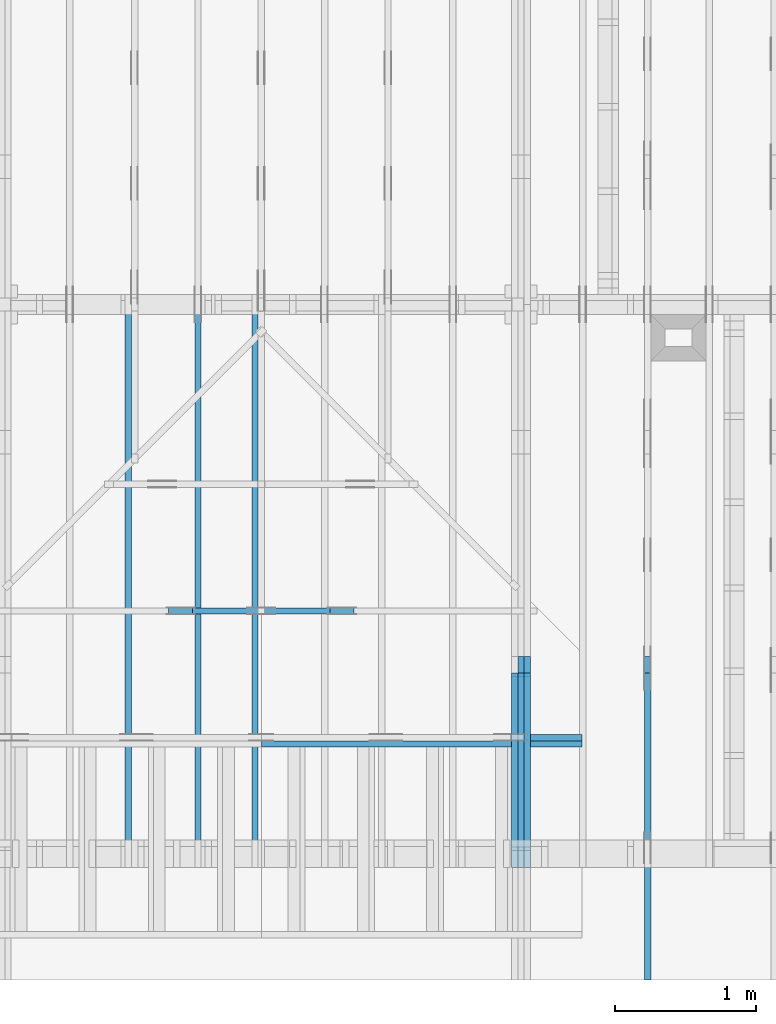
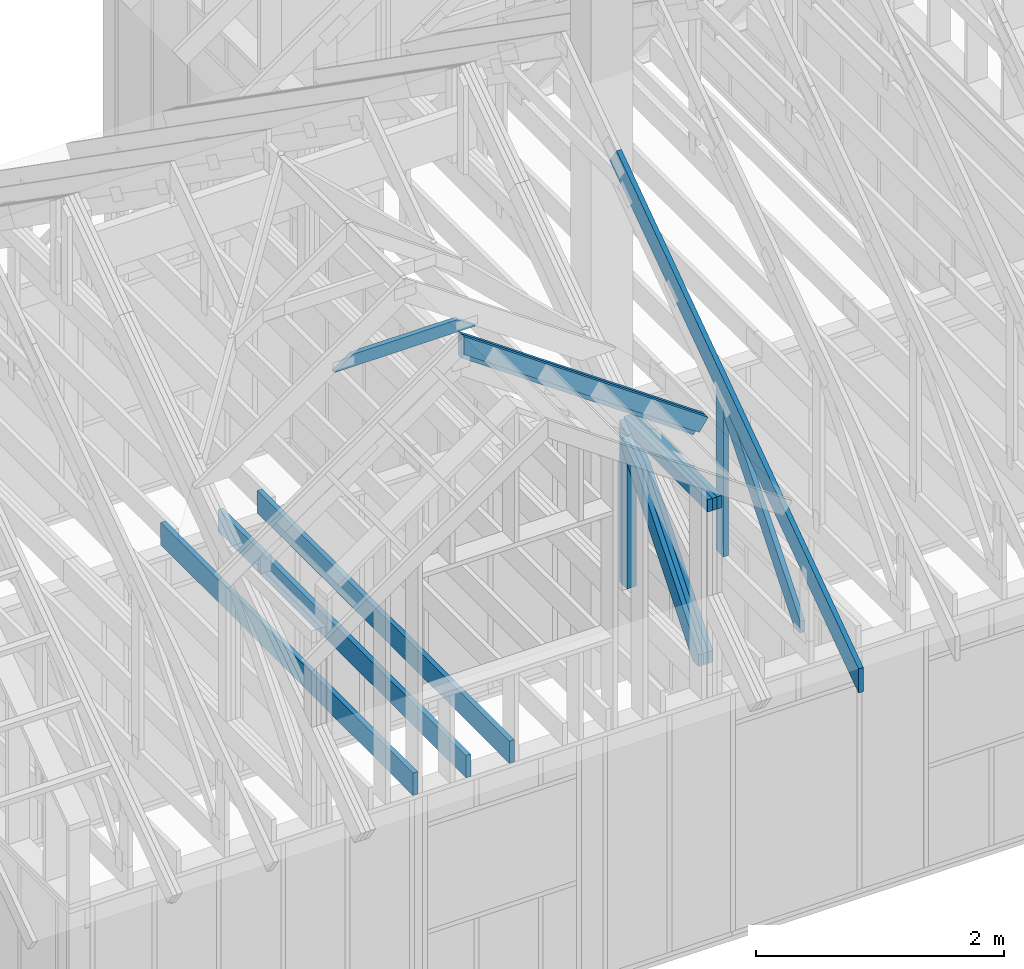
# One storey, part 8 of 70: 17 members, 8 elements without a shape of their own.
"""IFC2X3 building model written with IfcOpenShell, lengths in millimetres."""

from ifc_helpers import new_model, si_unit, frame, origin, origin_with_axes, origin_2d, place, context, project, spatial, faceted_brep, element, aggregate, save


model = new_model("IFC2X3")

# Units and contexts
model_context = context("Model", 3, precision=1e-05, world=origin())
plan_context = context("Plan", 2, precision=1e-05, world=origin_2d())
ifc_project = project(units=[si_unit("LENGTHUNIT", "METRE", prefix="MILLI"), si_unit("AREAUNIT", "SQUARE_METRE"), si_unit("VOLUMEUNIT", "CUBIC_METRE"), si_unit("SOLIDANGLEUNIT", "STERADIAN"), si_unit("PLANEANGLEUNIT", "RADIAN"), si_unit("MASSUNIT", "GRAM"), si_unit("TIMEUNIT", "SECOND"), si_unit("THERMODYNAMICTEMPERATUREUNIT", "DEGREE_CELSIUS"), si_unit("LUMINOUSINTENSITYUNIT", "LUMEN")], contexts=[model_context, plan_context])

# Site, building, storey
site_placement = place(None, origin_with_axes())
site = spatial("IfcSite", under=ifc_project, at=site_placement, CompositionType="ELEMENT")
building_placement = place(site_placement, origin_with_axes())
building = spatial("IfcBuilding", under=site, at=building_placement, Name="Layout 1", CompositionType="ELEMENT")
storey_placement = place(building_placement, origin_with_axes())
storey = spatial("IfcBuildingStorey", under=building, at=storey_placement, Name="Storey 1", CompositionType="ELEMENT", Elevation=0.0)

# Assembly, members
assembly_1_placement = place(storey_placement, frame((5660.000000000293, 8000.0, 9.122500660690286e-13), z_axis=(-1.0, 1.836909530733566e-16, 6.123031769111886e-17), x_axis=(-1.836909530733566e-16, -1.0, 0.0)))
assembly_1 = element("IfcElementAssembly", 1, at=assembly_1_placement, inside=storey, Name="T11", AssemblyPlace="FACTORY", PredefinedType="TRUSS")
member_1_placement = place(assembly_1_placement, frame((6619.9999999949505, 219.99999999999994, -135.0), z_axis=(0.0, 0.0, 1.0), x_axis=(5.053195275411815e-16, 1.0, 0.0)))
member_1 = element("IfcMember", 2, at=member_1_placement, Name="R1", context=model_context, shape_type="Brep", body=[
    faceted_brep([(1592.2602625099316, 120.00000000000091, 45.0), (0.0, 120.00000000000091, 45.0), (5.684341886080802e-14, 0.0, 45.0), (1508.2353579246992, 0.0, 45.0), (0.0, 120.00000000000091, 0.0), (1592.2602625099316, 120.00000000000091, 1.9498920344085486e-13), (1508.2353579246992, 0.0, 1.846994602374154e-13), (5.684341886080802e-14, 0.0, 6.961081190993225e-30), (5.684341886080802e-14, 0.0, 0.0), (5.959878315690836e-14, 8.86203890694297e-31, 45.0), (2.1003354220769377e-14, 120.0, 45.0), (1.8247989924669028e-14, 120.0, -1.1173302203118208e-30), (1508.2353579246992, -2.7704919035612314e-13, 7.265245946951848e-29), (1508.2353579246992, -2.742938260600228e-13, 45.0), (5.684341886080802e-14, 2.7553642961003043e-15, 45.0), (5.684341886080802e-14, -4.4719288075722504e-29, 2.7381762157971524e-45), (1592.260262509932, 120.00000000000057, 1.9009198412843567e-29), (1592.260262509932, 120.00000000000057, 45.0), (1508.2353579246997, 6.821210263296962e-13, 45.0), (1508.2353579246997, 6.821210263296962e-13, 3.2533805409343593e-29), (0.0, 120.0, 0.0), (0.0, 120.0, 45.0), (1592.2602625099316, 120.00000000000131, 45.0), (1592.2602625099316, 120.00000000000132, 2.524354896707238e-29)], [[[0, 1, 2, 3]], [[4, 5, 6, 7]], [[8, 9, 10, 11]], [[12, 13, 14, 15]], [[16, 17, 18, 19]], [[20, 21, 22, 23]]]),
])
member_2_placement = place(assembly_1_placement, frame((6619.9999999949505, 219.99999999999994, -180.0), z_axis=(0.0, 0.0, 1.0), x_axis=(5.053195275411815e-16, 1.0, 0.0)))
member_2 = element("IfcMember", 3, at=member_2_placement, Name="R1", context=model_context, shape_type="Brep", body=[
    faceted_brep([(1592.2602625099316, 120.00000000000091, 45.0), (0.0, 120.00000000000091, 45.0), (5.684341886080802e-14, 0.0, 45.0), (1508.2353579246992, 0.0, 45.0), (0.0, 120.00000000000091, 0.0), (1592.2602625099316, 120.00000000000091, 1.9498920344085486e-13), (1508.2353579246992, 0.0, 1.846994602374154e-13), (5.684341886080802e-14, 0.0, 6.961081190993225e-30), (5.684341886080802e-14, 0.0, 0.0), (5.959878315690836e-14, 8.86203890694297e-31, 45.0), (2.1003354220769377e-14, 120.0, 45.0), (1.8247989924669028e-14, 120.0, -1.1173302203118208e-30), (1508.2353579246992, -2.7704919035612314e-13, 7.265245946951848e-29), (1508.2353579246992, -2.742938260600228e-13, 45.0), (5.684341886080802e-14, 2.7553642961003043e-15, 45.0), (5.684341886080802e-14, -4.4719288075722504e-29, 2.7381762157971524e-45), (1592.260262509932, 120.00000000000057, 1.9009198412843567e-29), (1592.260262509932, 120.00000000000057, 45.0), (1508.2353579246997, 6.821210263296962e-13, 45.0), (1508.2353579246997, 6.821210263296962e-13, 3.2533805409343593e-29), (0.0, 120.0, 0.0), (0.0, 120.0, 45.0), (1592.2602625099316, 120.00000000000131, 45.0), (1592.2602625099316, 120.00000000000132, 2.524354896707238e-29)], [[[0, 1, 2, 3]], [[4, 5, 6, 7]], [[8, 9, 10, 11]], [[12, 13, 14, 15]], [[16, 17, 18, 19]], [[20, 21, 22, 23]]]),
])
member_3_placement = place(assembly_1_placement, frame((6563.906131857986, 1682.303582896796, -90.00000000000001), z_axis=(0.0, 0.0, 1.0), x_axis=(0.6335417245359882, -0.7737085260432164, 0.0)))
member_3 = element("IfcMember", 4, at=member_3_placement, Name="W6", context=model_context, shape_type="Brep", body=[
    faceted_brep([(1860.8184531642582, 145.00000000000364, 45.0), (258.1329393215924, 145.00000000000364, 45.0), (0.0, 72.49999999849206, 45.0), (88.54013234574177, 0.0, 45.0), (1889.9928508932062, 0.0, 45.0), (1949.358585511326, 72.49999999849206, 45.0), (258.1329393215924, 145.00000000000364, 3.1611123762406824e-14), (1860.8184531642582, 145.00000000000364, 2.2787701010548785e-13), (1949.358585511326, 72.49999999849206, 2.3871969096953717e-13), (1889.9928508932062, 0.0, 2.3144972538826894e-13), (88.54013234574177, 0.0, 1.0842680863886955e-14), (0.0, 72.49999999849206, 0.0), (7.105427357601002e-15, 72.49999999849206, 1.7516230804060213e-46), (7.105427357601002e-15, 72.49999999849206, 45.0), (258.13293932159246, 145.0, 45.0), (258.13293932159246, 145.0, 1.7516230804060213e-46), (88.54013234574177, -2.842170943040401e-14, 2.3665827156630354e-30), (88.54013234574177, -2.842170943040401e-14, 45.0), (7.105427357601002e-15, 72.49999999849209, 45.0), (7.105427357601002e-15, 72.49999999849209, -1.1832913578315177e-30), (1889.9928508932062, 2.7866220188636956e-12, 1.0781749613963793e-28), (1889.9928508932062, 2.789377383159796e-12, 45.0), (88.54013234574177, -7.973490750159428e-14, 45.0), (88.54013234574177, -8.249027179769463e-14, 5.0509055485995835e-30), (1949.358585511326, 72.50000000000239, 1.262177448353619e-29), (1949.358585511326, 72.50000000000239, 45.0), (1889.9928508932062, 4.206412995699793e-12, 45.0), (1889.9928508932062, 4.206412995699793e-12, 1.262177448353619e-29), (1860.8184531642582, 145.00000000000364, -1.262177448353619e-29), (1860.8184531642582, 145.00000000000364, 45.0), (1949.358585511326, 72.50000000000261, 45.0), (1949.358585511326, 72.50000000000261, -1.262177448353619e-29), (258.1329393215924, 144.99999999999997, -1.5777218104420236e-30), (258.1329393215924, 144.99999999999997, 45.0), (1860.8184531642582, 145.0000000000034, 45.0), (1860.8184531642582, 145.0000000000034, -1.262177448353619e-29)], [[[0, 1, 2, 3, 4, 5]], [[6, 7, 8, 9, 10, 11]], [[12, 13, 14, 15]], [[16, 17, 18, 19]], [[20, 21, 22, 23]], [[24, 25, 26, 27]], [[28, 29, 30, 31]], [[32, 33, 34, 35]]]),
])
member_4_placement = place(assembly_1_placement, frame((6563.906131857986, 1682.303582896796, -135.00000000000003), z_axis=(0.0, 0.0, 1.0), x_axis=(0.6335417245359882, -0.7737085260432164, 0.0)))
member_4 = element("IfcMember", 5, at=member_4_placement, Name="W6", context=model_context, shape_type="Brep", body=[
    faceted_brep([(1860.8184531642582, 145.00000000000364, 45.0), (258.1329393215924, 145.00000000000364, 45.0), (0.0, 72.49999999849206, 45.0), (88.54013234574177, 0.0, 45.0), (1889.9928508932062, 0.0, 45.0), (1949.358585511326, 72.49999999849206, 45.0), (258.1329393215924, 145.00000000000364, 3.1611123762406824e-14), (1860.8184531642582, 145.00000000000364, 2.2787701010548785e-13), (1949.358585511326, 72.49999999849206, 2.3871969096953717e-13), (1889.9928508932062, 0.0, 2.3144972538826894e-13), (88.54013234574177, 0.0, 1.0842680863886955e-14), (0.0, 72.49999999849206, 0.0), (7.105427357601002e-15, 72.49999999849206, 1.7516230804060213e-46), (7.105427357601002e-15, 72.49999999849206, 45.0), (258.13293932159246, 145.0, 45.0), (258.13293932159246, 145.0, 1.7516230804060213e-46), (88.54013234574177, -2.842170943040401e-14, 2.3665827156630354e-30), (88.54013234574177, -2.842170943040401e-14, 45.0), (7.105427357601002e-15, 72.49999999849209, 45.0), (7.105427357601002e-15, 72.49999999849209, -1.1832913578315177e-30), (1889.9928508932062, 2.7866220188636956e-12, 1.0781749613963793e-28), (1889.9928508932062, 2.789377383159796e-12, 45.0), (88.54013234574177, -7.973490750159428e-14, 45.0), (88.54013234574177, -8.249027179769463e-14, 5.0509055485995835e-30), (1949.358585511326, 72.50000000000239, 1.262177448353619e-29), (1949.358585511326, 72.50000000000239, 45.0), (1889.9928508932062, 4.206412995699793e-12, 45.0), (1889.9928508932062, 4.206412995699793e-12, 1.262177448353619e-29), (1860.8184531642582, 145.00000000000364, -1.262177448353619e-29), (1860.8184531642582, 145.00000000000364, 45.0), (1949.358585511326, 72.50000000000261, 45.0), (1949.358585511326, 72.50000000000261, -1.262177448353619e-29), (258.1329393215924, 144.99999999999997, -1.5777218104420236e-30), (258.1329393215924, 144.99999999999997, 45.0), (1860.8184531642582, 145.0000000000034, 45.0), (1860.8184531642582, 145.0000000000034, -1.262177448353619e-29)], [[[0, 1, 2, 3, 4, 5]], [[6, 7, 8, 9, 10, 11]], [[12, 13, 14, 15]], [[16, 17, 18, 19]], [[20, 21, 22, 23]], [[24, 25, 26, 27]], [[28, 29, 30, 31]], [[32, 33, 34, 35]]]),
])
member_5_placement = place(assembly_1_placement, frame((6563.906131857986, 1682.303582896796, -180.00000000000003), z_axis=(0.0, 0.0, 1.0), x_axis=(0.6335417245359882, -0.7737085260432164, 0.0)))
member_5 = element("IfcMember", 6, at=member_5_placement, Name="W6", context=model_context, shape_type="Brep", body=[
    faceted_brep([(1860.8184531642582, 145.00000000000364, 45.0), (258.1329393215924, 145.00000000000364, 45.0), (0.0, 72.49999999849206, 45.0), (88.54013234574177, 0.0, 45.0), (1889.9928508932062, 0.0, 45.0), (1949.358585511326, 72.49999999849206, 45.0), (258.1329393215924, 145.00000000000364, 3.1611123762406824e-14), (1860.8184531642582, 145.00000000000364, 2.2787701010548785e-13), (1949.358585511326, 72.49999999849206, 2.3871969096953717e-13), (1889.9928508932062, 0.0, 2.3144972538826894e-13), (88.54013234574177, 0.0, 1.0842680863886955e-14), (0.0, 72.49999999849206, 0.0), (7.105427357601002e-15, 72.49999999849206, 1.7516230804060213e-46), (7.105427357601002e-15, 72.49999999849206, 45.0), (258.13293932159246, 145.0, 45.0), (258.13293932159246, 145.0, 1.7516230804060213e-46), (88.54013234574177, -2.842170943040401e-14, 2.3665827156630354e-30), (88.54013234574177, -2.842170943040401e-14, 45.0), (7.105427357601002e-15, 72.49999999849209, 45.0), (7.105427357601002e-15, 72.49999999849209, -1.1832913578315177e-30), (1889.9928508932062, 2.7866220188636956e-12, 1.0781749613963793e-28), (1889.9928508932062, 2.789377383159796e-12, 45.0), (88.54013234574177, -7.973490750159428e-14, 45.0), (88.54013234574177, -8.249027179769463e-14, 5.0509055485995835e-30), (1949.358585511326, 72.50000000000239, 1.262177448353619e-29), (1949.358585511326, 72.50000000000239, 45.0), (1889.9928508932062, 4.206412995699793e-12, 45.0), (1889.9928508932062, 4.206412995699793e-12, 1.262177448353619e-29), (1860.8184531642582, 145.00000000000364, -1.262177448353619e-29), (1860.8184531642582, 145.00000000000364, 45.0), (1949.358585511326, 72.50000000000261, 45.0), (1949.358585511326, 72.50000000000261, -1.262177448353619e-29), (258.1329393215924, 144.99999999999997, -1.5777218104420236e-30), (258.1329393215924, 144.99999999999997, 45.0), (1860.8184531642582, 145.0000000000034, 45.0), (1860.8184531642582, 145.0000000000034, -1.262177448353619e-29)], [[[0, 1, 2, 3, 4, 5]], [[6, 7, 8, 9, 10, 11]], [[12, 13, 14, 15]], [[16, 17, 18, 19]], [[20, 21, 22, 23]], [[24, 25, 26, 27]], [[28, 29, 30, 31]], [[32, 33, 34, 35]]]),
])
member_6_placement = place(assembly_1_placement, frame((8000.000000000239, 1950.43961597234, -90.0), z_axis=(0.0, 0.0, 1.0), x_axis=(-1.0, -7.792541026514777e-13, 0.0)))
member_6 = element("IfcMember", 7, at=member_6_placement, Name="T20", context=model_context, shape_type="Brep", body=[
    faceted_brep([(1185.9906822582107, 120.00000000718114, 45.0), (0.0, 120.00000000718114, 45.0), (2.3919710656628013e-10, 0.0, 45.0), (1357.3684430670319, 0.0, 45.0), (0.0, 120.00000000718114, 0.0), (1185.9906822582107, 120.00000000718114, 1.452371725067541e-13), (1357.3684430670319, 0.0, 1.662242019857875e-13), (2.3919710656628013e-10, 0.0, 2.929222965169949e-26), (2.3919710656628013e-10, 0.0, 0.0), (2.3919986193057623e-10, 5.491303034653426e-27, 45.0), (4.5872349972372883e-14, 120.0, 45.0), (4.3116985676272535e-14, 120.0, -2.6400667308415888e-30), (1357.3684430670319, 7.185039401631766e-09, 5.377473518020143e-29), (1357.3684430670319, 7.185042156996062e-09, 45.0), (2.3919710656628013e-10, 2.755364295945585e-15, 45.0), (2.3919710656628013e-10, -1.5476399835663503e-25, 9.476248786526727e-42), (1185.9906822582107, 120.00000000718126, 7.47707513912535e-31), (1185.9906822582107, 120.00000000718126, 45.0), (1357.3684430670319, 7.185803951870184e-09, 45.0), (1357.3684430670319, 7.185803951870184e-09, -5.4167093989721165e-31), (0.0, 120.0, 0.0), (0.0, 120.0, 45.0), (1185.9906822582107, 120.00000000718101, 45.0), (1185.9906822582107, 120.00000000718103, -6.310887241768095e-30)], [[[0, 1, 2, 3]], [[4, 5, 6, 7]], [[8, 9, 10, 11]], [[12, 13, 14, 15]], [[16, 17, 18, 19]], [[20, 21, 22, 23]]]),
])
member_7_placement = place(assembly_1_placement, frame((8000.000000000239, 1950.43961597234, -135.0), z_axis=(0.0, 0.0, 1.0), x_axis=(-1.0, -7.792541026514777e-13, 0.0)))
member_7 = element("IfcMember", 8, at=member_7_placement, Name="T20", context=model_context, shape_type="Brep", body=[
    faceted_brep([(1185.9906822582107, 120.00000000718114, 45.0), (0.0, 120.00000000718114, 45.0), (2.3919710656628013e-10, 0.0, 45.0), (1357.3684430670319, 0.0, 45.0), (0.0, 120.00000000718114, 0.0), (1185.9906822582107, 120.00000000718114, 1.452371725067541e-13), (1357.3684430670319, 0.0, 1.662242019857875e-13), (2.3919710656628013e-10, 0.0, 2.929222965169949e-26), (2.3919710656628013e-10, 0.0, 0.0), (2.3919986193057623e-10, 5.491303034653426e-27, 45.0), (4.5872349972372883e-14, 120.0, 45.0), (4.3116985676272535e-14, 120.0, -2.6400667308415888e-30), (1357.3684430670319, 7.185039401631766e-09, 5.377473518020143e-29), (1357.3684430670319, 7.185042156996062e-09, 45.0), (2.3919710656628013e-10, 2.755364295945585e-15, 45.0), (2.3919710656628013e-10, -1.5476399835663503e-25, 9.476248786526727e-42), (1185.9906822582107, 120.00000000718126, 7.47707513912535e-31), (1185.9906822582107, 120.00000000718126, 45.0), (1357.3684430670319, 7.185803951870184e-09, 45.0), (1357.3684430670319, 7.185803951870184e-09, -5.4167093989721165e-31), (0.0, 120.0, 0.0), (0.0, 120.0, 45.0), (1185.9906822582107, 120.00000000718101, 45.0), (1185.9906822582107, 120.00000000718103, -6.310887241768095e-30)], [[[0, 1, 2, 3]], [[4, 5, 6, 7]], [[8, 9, 10, 11]], [[12, 13, 14, 15]], [[16, 17, 18, 19]], [[20, 21, 22, 23]]]),
])
member_8_placement = place(assembly_1_placement, frame((8000.000000000239, 1950.43961597234, -180.0), z_axis=(0.0, 0.0, 1.0), x_axis=(-1.0, -7.792541026514777e-13, 0.0)))
member_8 = element("IfcMember", 9, at=member_8_placement, Name="T20", context=model_context, shape_type="Brep", body=[
    faceted_brep([(1185.9906822582107, 120.00000000718114, 45.0), (0.0, 120.00000000718114, 45.0), (2.3919710656628013e-10, 0.0, 45.0), (1357.3684430670319, 0.0, 45.0), (0.0, 120.00000000718114, 0.0), (1185.9906822582107, 120.00000000718114, 1.452371725067541e-13), (1357.3684430670319, 0.0, 1.662242019857875e-13), (2.3919710656628013e-10, 0.0, 2.929222965169949e-26), (2.3919710656628013e-10, 0.0, 0.0), (2.3919986193057623e-10, 5.491303034653426e-27, 45.0), (4.5872349972372883e-14, 120.0, 45.0), (4.3116985676272535e-14, 120.0, -2.6400667308415888e-30), (1357.3684430670319, 7.185039401631766e-09, 5.377473518020143e-29), (1357.3684430670319, 7.185042156996062e-09, 45.0), (2.3919710656628013e-10, 2.755364295945585e-15, 45.0), (2.3919710656628013e-10, -1.5476399835663503e-25, 9.476248786526727e-42), (1185.9906822582107, 120.00000000718126, 7.47707513912535e-31), (1185.9906822582107, 120.00000000718126, 45.0), (1357.3684430670319, 7.185803951870184e-09, 45.0), (1357.3684430670319, 7.185803951870184e-09, -5.4167093989721165e-31), (0.0, 120.0, 0.0), (0.0, 120.0, 45.0), (1185.9906822582107, 120.00000000718101, 45.0), (1185.9906822582107, 120.00000000718103, -6.310887241768095e-30)], [[[0, 1, 2, 3]], [[4, 5, 6, 7]], [[8, 9, 10, 11]], [[12, 13, 14, 15]], [[16, 17, 18, 19]], [[20, 21, 22, 23]]]),
])
aggregate(assembly_1, [member_1, member_2, member_3, member_4, member_5, member_6, member_7, member_8])

# Assembly, member
assembly_2_placement = place(storey_placement, frame((3455.0000000000005, 8000.000000000001, 1.3776821480501744e-15), z_axis=(-1.0, 1.836909530733566e-16, 6.123031769111886e-17), x_axis=(-1.836909530733566e-16, -1.0, 0.0)))
assembly_2 = element("IfcElementAssembly", 10, at=assembly_2_placement, inside=storey, Name="MB1", AssemblyPlace="FACTORY", PredefinedType="TRUSS")
member_9_placement = place(assembly_2_placement, frame((8000.000000000001, 220.0, -45.0), z_axis=(0.0, 0.0, 1.0), x_axis=(-1.0, 1.2246063538223773e-16, 0.0)))
member_9 = element("IfcMember", 11, at=member_9_placement, Name="B3", context=model_context, shape_type="Brep", body=[
    faceted_brep([(4000.0000000000005, 220.0000000000005, 45.0), (0.0, 220.0000000000005, 45.0), (0.0, 0.0, 45.0), (4000.0000000000005, 0.0, 45.0), (0.0, 220.0000000000005, 0.0), (4000.0000000000005, 220.0000000000005, 4.89842541528951e-13), (4000.0000000000005, 0.0, 4.89842541528951e-13), (0.0, 0.0, 0.0), (0.0, 0.0, 0.0), (2.755364296100349e-15, -3.3742366240998092e-31, 45.0), (2.969670408019265e-14, 220.0, 45.0), (2.69413397840923e-14, 220.0, -1.6496267940043512e-30), (4000.0000000000005, -7.347638122934265e-13, 7.631468701413364e-29), (4000.0000000000005, -7.320084479973261e-13, 45.0), (5.061354936149714e-31, 2.755364296100349e-15, 45.0), (0.0, 0.0, 0.0), (4000.0000000000005, 220.0000000000005, 0.0), (4000.0000000000005, 220.0000000000005, 45.0), (4000.0000000000005, 5.115907697472721e-13, 45.0), (4000.0000000000005, 5.115907697472721e-13, 0.0), (0.0, 220.0, 0.0), (0.0, 220.0, 45.0), (4000.0000000000005, 220.00000000000065, 45.0), (4000.0000000000005, 220.00000000000065, 7.888609052210118e-30)], [[[0, 1, 2, 3]], [[4, 5, 6, 7]], [[8, 9, 10, 11]], [[12, 13, 14, 15]], [[16, 17, 18, 19]], [[20, 21, 22, 23]]]),
])
aggregate(assembly_2, [member_9])

assembly_3_placement = place(storey_placement, frame((6205.00000000017, 945.0, 1.3776821480501744e-15), z_axis=(1.2246063538223773e-16, 1.0, 6.123031769111886e-17), x_axis=(-1.0, 1.2246063538223773e-16, 0.0)))
assembly_3 = element("IfcElementAssembly", 12, at=assembly_3_placement, inside=storey, Name="T7", AssemblyPlace="FACTORY", PredefinedType="TRUSS")
member_10_placement = place(assembly_3_placement, frame((111.84740508874393, 1910.1615822583046, -45.0), z_axis=(0.0, 0.0, 1.0), x_axis=(0.8191520442889916, 0.5735764363510464, 0.0)))
member_10 = element("IfcMember", 13, at=member_10_placement, Name="T14", context=model_context, shape_type="Brep", body=[
    faceted_brep([(2780.314125903724, 194.9999999995032, 45.0), (0.0, 194.9999999995032, 45.0), (3.9267433749046177e-10, 0.0, 45.0), (2643.7736559537752, 0.0, 45.0), (0.0, 194.9999999995032, 0.0), (2780.314125903724, 194.9999999995032, 3.404790344203809e-13), (2643.7736559537752, 0.0, 3.237582017149209e-13), (3.9267433749046177e-10, 0.0, 4.80871488673812e-26), (3.926743374904618e-10, 9.4039548065783e-38, -2.8698592549372254e-42), (3.926770928547579e-10, 5.5475899021902624e-27, 45.0), (6.837957290390364e-14, 195.00000000050545, 45.0), (6.56242086078033e-14, 195.00000000050545, -4.018191141284025e-30), (2643.7736559537752, 8.495420229172257e-10, 1.2077016536174847e-28), (2643.7736559537752, 8.495447782815218e-10, 45.0), (3.9267433749046177e-10, 2.7553642958073935e-15, 45.0), (3.9267433749046177e-10, -2.9295532543016987e-25, 1.7937747645394064e-41), (2780.3141259037243, 194.99999999950296, 5.048709793414476e-29), (2780.3141259037243, 194.99999999950296, 45.0), (2643.7736559537757, 8.512870408594608e-10, 45.0), (2643.7736559537757, 8.512870408594608e-10, 5.048709793414476e-29), (0.0, 195.00000000050545, 0.0), (0.0, 195.00000000050545, 45.0), (2780.314125903724, 194.9999999995033, 45.0), (2780.314125903724, 194.9999999995033, 7.888609052210118e-30)], [[[0, 1, 2, 3]], [[4, 5, 6, 7]], [[8, 9, 10, 11]], [[12, 13, 14, 15]], [[16, 17, 18, 19]], [[20, 21, 22, 23]]]),
])
aggregate(assembly_3, [member_10])

assembly_4_placement = place(storey_placement, frame((5910.470169573801, 1845.0, 1.3776821480501744e-15), z_axis=(1.2246063538223773e-16, 1.0, 6.123031769111886e-17), x_axis=(-1.0, 1.2246063538223773e-16, 0.0)))
assembly_4 = element("IfcElementAssembly", 14, at=assembly_4_placement, inside=storey, Name="T6", AssemblyPlace="FACTORY", PredefinedType="TRUSS")
member_11_placement = place(assembly_4_placement, frame((2642.157380753415, 3084.999999998777, -45.0), z_axis=(0.0, 0.0, 1.0), x_axis=(-1.0, 1.2246063538223773e-16, 0.0)))
member_11 = element("IfcMember", 15, at=member_11_placement, Name="C3", context=model_context, shape_type="Brep", body=[
    faceted_brep([(1318.3744223606627, 120.00000000000728, 45.0), (0.0, 120.00000000000728, 45.0), (171.37776080916228, 6.821210263296962e-12, 45.0), (1146.996661551806, 6.821210263296962e-12, 45.0), (0.0, 120.00000000000728, 0.0), (1318.3744223606627, 120.00000000000728, 1.6144896943397739e-13), (1146.996661551806, 6.821210263296962e-12, 1.4046193995493965e-13), (171.37776080916228, 6.821210263296962e-12, 2.0987029479075173e-14), (171.37776080916223, 6.750155989720952e-12, 5.5220263365470826e-30), (171.37776080916223, 6.750155989720952e-12, 45.0), (7.105427357601002e-15, 119.99999999999955, 45.0), (7.105427357601002e-15, 119.99999999999955, 0.0), (1146.996661551806, -3.4116650145363124e-13, 2.088973326957347e-29), (1146.996661551806, -3.384111371575309e-13, 45.0), (171.37776080916228, 6.772990456485663e-12, 45.0), (171.37776080916228, 6.770235092189562e-12, 3.1212259212651897e-30), (1318.3744223606627, 120.00000000000693, 2.6012554462568004e-29), (1318.3744223606627, 120.00000000000693, 45.0), (1146.996661551806, -2.2737367544323206e-13, 45.0), (1146.996661551806, -2.2737367544323206e-13, 1.841228876698994e-29), (0.0, 119.99999999999955, 0.0), (0.0, 119.99999999999955, 45.0), (1318.3744223606627, 120.00000000000736, 45.0), (1318.3744223606627, 120.00000000000738, 6.310887241768095e-30)], [[[0, 1, 2, 3]], [[4, 5, 6, 7]], [[8, 9, 10, 11]], [[12, 13, 14, 15]], [[16, 17, 18, 19]], [[20, 21, 22, 23]]]),
])
aggregate(assembly_4, [member_11])

# Assembly, members
assembly_5_placement = place(storey_placement, frame((6650.000000000001, 8000.0, -9.081170196248781e-13), z_axis=(-1.0, 1.836909530733566e-16, 6.123031769111886e-17), x_axis=(-1.836909530733566e-16, -1.0, 0.0)))
assembly_5 = element("IfcElementAssembly", 16, at=assembly_5_placement, inside=storey, Name="T12", AssemblyPlace="FACTORY", PredefinedType="TRUSS")
member_12_placement = place(assembly_5_placement, frame((4782.309641269037, 3015.0000000009313, -45.00000000000001), z_axis=(0.0, 0.0, 1.0), x_axis=(0.8191520442889916, -0.5735764363510465, 0.0)))
member_12 = element("IfcMember", 17, at=member_12_placement, Name="T8", context=model_context, shape_type="Brep", body=[
    faceted_brep([(4768.153825500143, 194.99999999946067, 45.0), (1.6370904631912708e-10, 194.99999999946067, 45.0), (0.0, 0.0, 45.0), (4904.694295450093, 0.0, 45.0), (1.6370904631912708e-10, 194.99999999946067, 2.004791383006049e-26), (4768.153825500143, 194.99999999946067, 5.83911147070995e-13), (4904.694295450093, 0.0, 6.006319797764552e-13), (0.0, 0.0, 0.0), (2.5849394142282115e-26, -2.1699301500556333e-38, -1.582766615454881e-42), (2.7553642961261982e-15, -2.3129934990511945e-27, 45.0), (1.6369571347777126e-10, 194.99999999920783, 45.0), (1.6369295811347516e-10, 194.99999999920783, 9.850859431479521e-31), (4904.694295450093, 8.093603669211206e-10, -5.018296283692949e-29), (4904.694295450093, 8.093631222854167e-10, 45.0), (-4.546833142611764e-28, 2.755364296100349e-15, 45.0), (0.0, 0.0, 0.0), (4768.153825500144, 194.99999999946112, 5.048709793414476e-29), (4768.153825500144, 194.99999999946112, 45.0), (4904.694295450094, 8.089955372270197e-10, 45.0), (4904.694295450094, 8.089955372270197e-10, 1.0097419586828951e-28), (1.637090463191271e-10, 194.99999999920783, 0.0), (1.637090463191271e-10, 194.99999999920783, 45.0), (4768.153825500143, 194.99999999946058, 45.0), (4768.153825500143, 194.99999999946058, -6.310887241768095e-30)], [[[0, 1, 2, 3]], [[4, 5, 6, 7]], [[8, 9, 10, 11]], [[12, 13, 14, 15]], [[16, 17, 18, 19]], [[20, 21, 22, 23]]]),
])
member_13_placement = place(assembly_5_placement, frame((6619.999999999389, 220.0, -45.0), z_axis=(0.0, 0.0, 1.0), x_axis=(6.123031769111886e-17, 1.0, 0.0)))
member_13 = element("IfcMember", 18, at=member_13_placement, Name="T5", context=model_context, shape_type="Brep", body=[
    faceted_brep([(1592.2602625068248, 120.0, 45.0), (0.0, 120.0, 45.0), (0.0, 1.4551915228366852e-11, 45.0), (1508.235357921585, 1.4551915228366852e-11, 45.0), (0.0, 120.0, 0.0), (1592.2602625068248, 120.0, 1.949892034404744e-13), (1508.235357921585, 1.4551915228366852e-11, 1.8469946023703405e-13), (0.0, 1.4551915228366852e-11, 0.0), (1.7820367848942657e-27, 1.4551915228366852e-11, -1.0911467847633593e-43), (2.755364296102131e-15, 1.4551915228366852e-11, 45.0), (1.7450640541968876e-14, 120.0, 45.0), (1.4695276245868527e-14, 120.0, -8.997964330932825e-31), (1508.235357921585, -4.605370260698061e-13, 2.81988284147774e-29), (1508.235357921585, -4.577816617737058e-13, 45.0), (2.7425941661909085e-29, 1.4554670592662952e-11, 45.0), (0.0, 1.4551915228366852e-11, 0.0), (1592.260262506825, 120.00000000000011, 1.262177448353619e-29), (1592.260262506825, 120.00000000000011, 45.0), (1508.2353579215853, 0.0, 45.0), (1508.2353579215853, 0.0, 1.262177448353619e-29), (0.0, 120.0, 0.0), (-1.6871183120499046e-31, 120.0, 45.0), (1592.2602625068248, 119.9999999999999, 45.0), (1592.2602625068248, 119.9999999999999, -6.310887241768095e-30)], [[[0, 1, 2, 3]], [[4, 5, 6, 7]], [[8, 9, 10, 11]], [[12, 13, 14, 15]], [[16, 17, 18, 19]], [[20, 21, 22, 23]]]),
])
member_14_placement = place(assembly_5_placement, frame((6563.906131861295, 1682.3035828927568, -45.00000000000001), z_axis=(0.0, 0.0, 1.0), x_axis=(0.6335417245359882, -0.7737085260432164, 0.0)))
member_14 = element("IfcMember", 19, at=member_14_placement, Name="W6", context=model_context, shape_type="Brep", body=[
    faceted_brep([(1860.8184531590405, 145.0, 45.0), (258.1329393189221, 145.0, 45.0), (0.0, 72.4999999999518, 45.0), (88.54013234752438, 0.0, 45.0), (1889.992850887983, 0.0, 45.0), (1949.3585855061046, 72.4999999999518, 45.0), (258.1329393189221, 145.0, 3.161112376207982e-14), (1860.8184531590405, 145.0, 2.278770101048489e-13), (1949.3585855061046, 72.4999999999518, 2.3871969096889775e-13), (1889.992850887983, 0.0, 2.3144972538762927e-13), (88.54013234752438, 0.0, 1.0842680864105255e-14), (0.0, 72.4999999999518, 0.0), (3.552713678800501e-15, 72.4999999999518, -8.492704648590562e-31), (3.552713678800501e-15, 72.4999999999518, 45.0), (258.1329393189221, 145.00000000000003, 45.0), (258.1329393189221, 145.00000000000003, 6.911006666987167e-31), (88.54013234752439, 0.0, 8.758115402030107e-47), (88.54013234752439, 0.0, 45.0), (0.0, 72.49999999995181, 45.0), (0.0, 72.4999999999518, 8.758115402030107e-47), (1889.992850887983, -3.918756121136429e-13, 7.968331775306583e-29), (1889.992850887983, -3.8912024781754257e-13, 45.0), (88.54013234752438, -5.820968103225653e-14, 45.0), (88.54013234752438, -6.096504532835688e-14, 3.7329090935087544e-30), (1949.358585506105, 72.50000000000159, 3.7865323450608567e-29), (1949.358585506105, 72.50000000000159, 45.0), (1889.9928508879834, 6.821210263296962e-13, 45.0), (1889.9928508879834, 6.821210263296962e-13, 3.7865323450608567e-29), (1860.8184531590405, 145.0, 0.0), (1860.8184531590405, 145.0, 45.0), (1949.3585855061046, 72.50000000000182, 45.0), (1949.3585855061046, 72.50000000000182, 1.262177448353619e-29), (258.1329393189221, 144.99999999999997, -1.5777218104420236e-30), (258.1329393189221, 144.99999999999997, 45.0), (1860.8184531590405, 144.9999999999999, 45.0), (1860.8184531590405, 144.9999999999999, -6.310887241768095e-30)], [[[0, 1, 2, 3, 4, 5]], [[6, 7, 8, 9, 10, 11]], [[12, 13, 14, 15]], [[16, 17, 18, 19]], [[20, 21, 22, 23]], [[24, 25, 26, 27]], [[28, 29, 30, 31]], [[32, 33, 34, 35]]]),
])
aggregate(assembly_5, [member_12, member_13, member_14])

# Assembly, member
assembly_6_placement = place(storey_placement, frame((3927.500000000029, -499.9999999997092, 3664.618899167738), z_axis=(0.5735764363510464, -1.1073377781974438e-17, 0.8191520442889916), x_axis=(0.8191520442889916, -3.512026741791439e-17, -0.5735764363510464)))
assembly_6 = element("IfcElementAssembly", 20, at=assembly_6_placement, inside=storey, Name="gs7", AssemblyPlace="FACTORY", PredefinedType="TRUSS")
member_15_placement = place(assembly_6_placement, frame((-4.122110170132127e-12, 1355.0, -145.0), z_axis=(0.0, 0.0, 1.0), x_axis=(1.0, 0.0, 0.0)))
member_15 = element("IfcMember", 21, at=member_15_placement, Name="T6", context=model_context, shape_type="Brep", body=[
    faceted_brep([(101.53009304103468, -1.3854578009645329e-11, -7.105427357601002e-15), (-1.4210854715202004e-14, 0.0, 144.9999999999971), (4.106937012693379e-12, 44.99999999999999, 145.0), (101.5300930410408, 44.999999999986144, 7.105427357601002e-15), (2780.3141259043655, -5.107185516306893e-13, 3.1271459167095196e-29), (2780.3141259043655, -5.01840155565477e-13, 145.0), (4.113844077243826e-12, 8.87839606521148e-15, 145.0), (101.53009304103469, -1.865015955633423e-14, 1.1419551946244014e-30), (101.53009304104083, 45.0, 1.2433439704223574e-14), (2780.3141259043655, 45.0, 3.404790344204595e-13), (2780.3141259043655, 0.0, 3.404790344204595e-13), (101.53009304103469, 0.0, 1.2433439704222821e-14), (4.122110170132127e-12, 44.99999999999999, 145.0), (2780.3141259043655, 44.99999999999982, 145.0), (2780.3141259043655, 44.99999999999983, -1.0255191767873153e-29), (101.53009304104083, 44.99999999999999, -3.944304526105059e-31), (2780.3141259043655, 45.0, 2.842170943040401e-14), (2780.3141259043655, 45.0, 145.0), (2780.3141259043655, 0.0, 145.0), (2780.3141259043655, 0.0, 0.0), (2780.3141259043655, 45.0, 145.0), (4.122110170132127e-12, 45.0, 145.0), (4.122110170132127e-12, 0.0, 145.0), (2780.3141259043655, 0.0, 145.0)], [[[0, 1, 2, 3]], [[4, 5, 6, 7]], [[8, 9, 10, 11]], [[12, 13, 14, 15]], [[16, 17, 18, 19]], [[20, 21, 22, 23]]]),
])
aggregate(assembly_6, [member_15])

assembly_7_placement = place(storey_placement, frame((2960.0000000000005, 4072.500000000002, 1.3776821480501744e-15), z_axis=(-1.0, 1.836909530733566e-16, 6.123031769111886e-17), x_axis=(-1.836909530733566e-16, -1.0, 0.0)))
assembly_7 = element("IfcElementAssembly", 22, at=assembly_7_placement, inside=storey, Name="MB2", AssemblyPlace="FACTORY", PredefinedType="TRUSS")
member_16_placement = place(assembly_7_placement, frame((4072.500000000002, 220.0, -45.0), z_axis=(0.0, 0.0, 1.0), x_axis=(-1.0, 1.2246063538223773e-16, 0.0)))
member_16 = element("IfcMember", 23, at=member_16_placement, Name="B2", context=model_context, shape_type="Brep", body=[
    faceted_brep([(4072.500000000002, 220.0000000000005, 45.0), (0.0, 220.0000000000005, 45.0), (0.0, 0.0, 45.0), (4072.500000000002, 0.0, 45.0), (0.0, 220.0000000000005, 0.0), (4072.500000000002, 220.0000000000005, 4.987209375941633e-13), (4072.500000000002, 0.0, 4.987209375941633e-13), (0.0, 0.0, 0.0), (0.0, 0.0, 0.0), (2.755364296100349e-15, -3.3742366240998092e-31, 45.0), (2.969670408019265e-14, 220.0, 45.0), (2.69413397840923e-14, 220.0, -1.6496267940043512e-30), (4072.500000000002, -7.48081406391245e-13, 7.713012753162445e-29), (4072.500000000002, -7.453260420951447e-13, 45.0), (5.061354936149714e-31, 2.755364296100349e-15, 45.0), (0.0, 0.0, 0.0), (4072.500000000002, 220.0000000000005, 0.0), (4072.500000000002, 220.0000000000005, 45.0), (4072.500000000002, 5.115907697472721e-13, 45.0), (4072.500000000002, 5.115907697472721e-13, 0.0), (0.0, 220.0, 0.0), (0.0, 220.0, 45.0), (4072.500000000002, 220.00000000000065, 45.0), (4072.500000000002, 220.00000000000065, 7.888609052210118e-30)], [[[0, 1, 2, 3]], [[4, 5, 6, 7]], [[8, 9, 10, 11]], [[12, 13, 14, 15]], [[16, 17, 18, 19]], [[20, 21, 22, 23]]]),
])
aggregate(assembly_7, [member_16])

assembly_8_placement = place(storey_placement, frame((3860.0000000000005, 4072.500000000002, 1.3776821480501744e-15), z_axis=(-1.0, 1.836909530733566e-16, 6.123031769111886e-17), x_axis=(-1.836909530733566e-16, -1.0, 0.0)))
assembly_8 = element("IfcElementAssembly", 24, at=assembly_8_placement, inside=storey, Name="MB2", AssemblyPlace="FACTORY", PredefinedType="TRUSS")
member_17_placement = place(assembly_8_placement, frame((4072.500000000002, 220.0, -45.0), z_axis=(0.0, 0.0, 1.0), x_axis=(-1.0, 1.2246063538223773e-16, 0.0)))
member_17 = element("IfcMember", 25, at=member_17_placement, Name="B2", context=model_context, shape_type="Brep", body=[
    faceted_brep([(4072.500000000002, 220.0000000000005, 45.0), (0.0, 220.0000000000005, 45.0), (0.0, 0.0, 45.0), (4072.500000000002, 0.0, 45.0), (0.0, 220.0000000000005, 0.0), (4072.500000000002, 220.0000000000005, 4.987209375941633e-13), (4072.500000000002, 0.0, 4.987209375941633e-13), (0.0, 0.0, 0.0), (0.0, 0.0, 0.0), (2.755364296100349e-15, -3.3742366240998092e-31, 45.0), (2.969670408019265e-14, 220.0, 45.0), (2.69413397840923e-14, 220.0, -1.6496267940043512e-30), (4072.500000000002, -7.48081406391245e-13, 7.713012753162445e-29), (4072.500000000002, -7.453260420951447e-13, 45.0), (5.061354936149714e-31, 2.755364296100349e-15, 45.0), (0.0, 0.0, 0.0), (4072.500000000002, 220.0000000000005, 0.0), (4072.500000000002, 220.0000000000005, 45.0), (4072.500000000002, 5.115907697472721e-13, 45.0), (4072.500000000002, 5.115907697472721e-13, 0.0), (0.0, 220.0, 0.0), (0.0, 220.0, 45.0), (4072.500000000002, 220.00000000000065, 45.0), (4072.500000000002, 220.00000000000065, 7.888609052210118e-30)], [[[0, 1, 2, 3]], [[4, 5, 6, 7]], [[8, 9, 10, 11]], [[12, 13, 14, 15]], [[16, 17, 18, 19]], [[20, 21, 22, 23]]]),
])
aggregate(assembly_8, [member_17])

save(model, "model.ifc")
